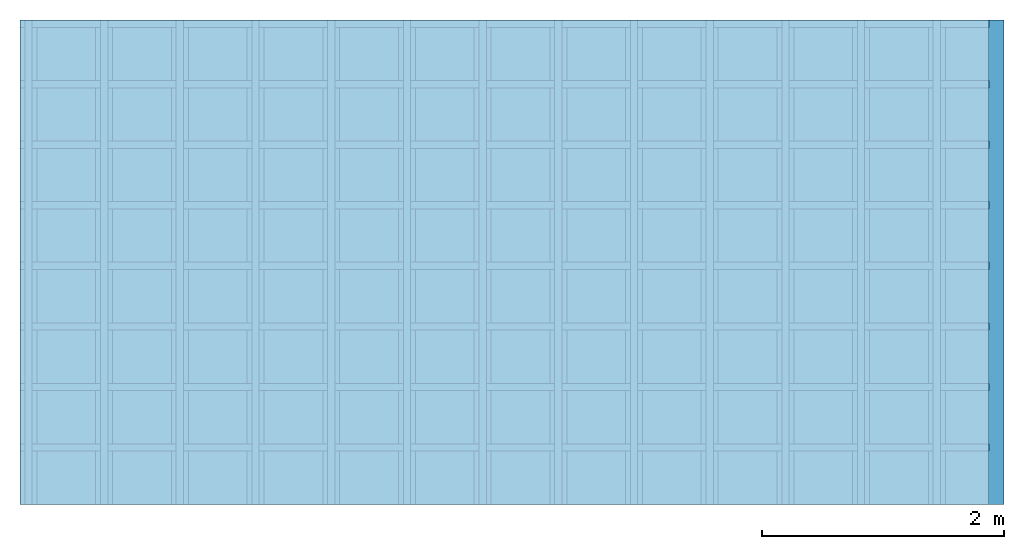
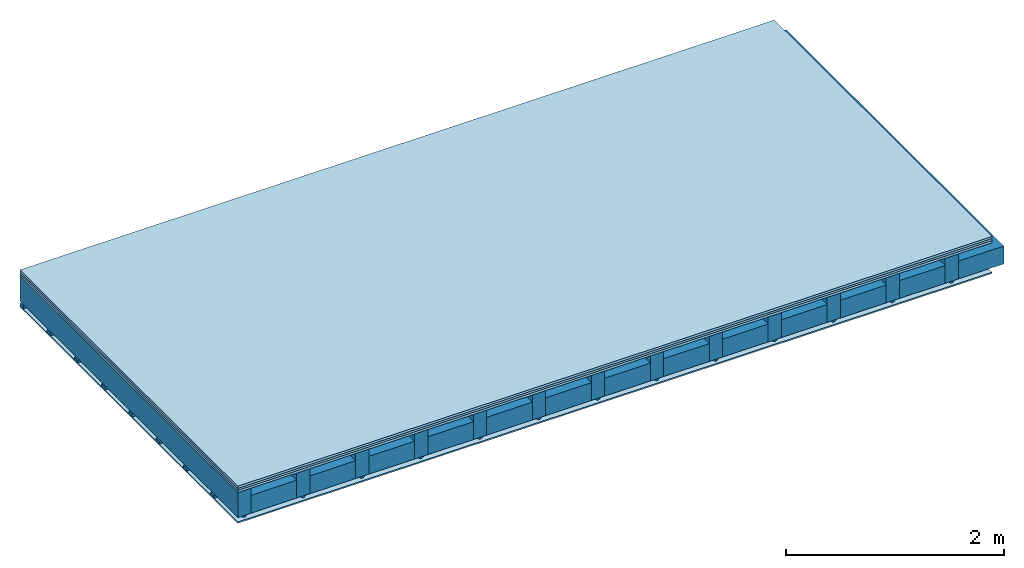
# One storey: 4 members, 4 plates, 1 element without a shape of its own.
"""IFC4 building model written with IfcOpenShell, lengths in metres."""

from ifc_helpers import new_model, si_unit, derived_unit, direction, frame, frame_2d, origin, origin_with_axes, place, context, project, spatial, polyline, rectangle, outline, extrude, material, layer, layer_set, type_object, element, aggregate, save


model = new_model("IFC4")

# Units and contexts
plan_context = context("Plan", 3, precision=1e-05, world=origin(), true_north=direction((0.0, 1.0)))
model_context = context("Model", 3, precision=1e-05, world=origin(), true_north=direction((0.0, 1.0)))
ifc_project = project(units=[si_unit("LENGTHUNIT", "METRE"), derived_unit("SOUNDPRESSUREUNIT", [(si_unit("PRESSUREUNIT", "PASCAL", prefix="MICRO"), 0)]), si_unit("ENERGYUNIT", "JOULE", prefix="MEGA"), si_unit("MASSUNIT", "GRAM", prefix="KILO"), derived_unit("THERMALTRANSMITTANCEUNIT", [(si_unit("POWERUNIT", "WATT"), 1), (si_unit("AREAUNIT", "SQUARE_METRE"), -1), (si_unit("THERMODYNAMICTEMPERATUREUNIT", "KELVIN"), -1)]), derived_unit("AREADENSITYUNIT", [(si_unit("MASSUNIT", "GRAM", prefix="KILO"), 1), (si_unit("AREAUNIT", "SQUARE_METRE"), -1)]), derived_unit("USERDEFINED", [(si_unit("ENERGYUNIT", "JOULE", prefix="MEGA"), 1), (si_unit("AREAUNIT", "SQUARE_METRE"), -1)])], contexts=[plan_context, model_context])

# Site, building, storey
site = spatial("IfcSite", under=ifc_project)
building_placement = place(None, origin())
building = spatial("IfcBuilding", under=site, at=building_placement)
storey_placement = place(building_placement, origin())
storey = spatial("IfcBuildingStorey", under=building, at=storey_placement)

# Slab, members, plates
ifc_material_1 = material(Name="Floor heating system Therm38 longitudinal", Category="03.007")
ifc_layer_1 = layer(ifc_material_1, 0.025, Name="On-material")
ifc_material_2 = material(Category="10.009")
ifc_layer_2 = layer(ifc_material_2, 0.022, Name="Impact sound insulation")
ifc_material_3 = material(Category="07.001")
ifc_layer_3 = layer(ifc_material_3, 0.025, Name="Sub-floor")
ifc_material_4 = material(Name="of the art")
ifc_layer_4 = layer(ifc_material_4, 0.0, Name="Bond")
ifc_layer_5 = layer(None, 0.28, Name="Supporting structure")
ifc_material_5 = material(Name="no composite action")
ifc_layer_6 = layer(ifc_material_5, 0.0, Name="Bond")
ifc_layer_7 = layer(None, 0.02, Name="Coupling")
ifc_layer_8 = layer(None, 0.03, Name="Battens / profiles")
ifc_material_6 = material(Name="Plasterboard type A", Category="03.008")
ifc_layer_9 = layer(ifc_material_6, 0.015, Name="Ceiling covering 1st layer")
ifc_material_7 = material(Name="joints", Category="04.017")
ifc_layer_10 = layer(ifc_material_7, 0.0, Name="Surface / treatment")
ifc_layer_set = layer_set([ifc_layer_1, ifc_layer_2, ifc_layer_3, ifc_layer_4, ifc_layer_5, ifc_layer_6, ifc_layer_7, ifc_layer_8, ifc_layer_9, ifc_layer_10])
slab_type = type_object("IfcSlabType", Name="A0139", PredefinedType="NOTDEFINED", material=ifc_layer_set)
slab_placement = place(None, frame((0.0, 0.0, 0.0), z_axis=(0.0, 0.0, -1.0), x_axis=(1.0, 0.0, 0.0)))
slab = element("IfcSlab", 1, at=slab_placement, inside=storey, type_object=slab_type, material=ifc_layer_set, Name="Slab #1")
ifc_material_8 = material()
member_1_placement = place(slab_placement, origin())
member_1 = element("IfcMember", 2, at=member_1_placement, material=ifc_material_8, Name="Supporting structure", context=plan_context, shape_type="SweptSolid", body=[
    extrude(rectangle(XDim=0.14, YDim=0.28, at=frame_2d((0.07, 0.14), x_axis=(1.0, 0.0))), frame((0.0, 4.0, 0.072), z_axis=(0.0, -1.0, 0.0), x_axis=(1.0, 0.0, 0.0)), (0.0, 0.0, 1.0), 4.0),
    extrude(rectangle(XDim=0.14, YDim=0.28, at=frame_2d((0.07, 0.14), x_axis=(1.0, 0.0))), frame((0.625, 4.0, 0.072), z_axis=(0.0, -1.0, 0.0), x_axis=(1.0, 0.0, 0.0)), (0.0, 0.0, 1.0), 4.0),
    extrude(rectangle(XDim=0.14, YDim=0.28, at=frame_2d((0.07, 0.14), x_axis=(1.0, 0.0))), frame((1.25, 4.0, 0.072), z_axis=(0.0, -1.0, 0.0), x_axis=(1.0, 0.0, 0.0)), (0.0, 0.0, 1.0), 4.0),
    extrude(rectangle(XDim=0.14, YDim=0.28, at=frame_2d((0.07, 0.14), x_axis=(1.0, 0.0))), frame((1.875, 4.0, 0.072), z_axis=(0.0, -1.0, 0.0), x_axis=(1.0, 0.0, 0.0)), (0.0, 0.0, 1.0), 4.0),
    extrude(rectangle(XDim=0.14, YDim=0.28, at=frame_2d((0.07, 0.14), x_axis=(1.0, 0.0))), frame((2.5, 4.0, 0.072), z_axis=(0.0, -1.0, 0.0), x_axis=(1.0, 0.0, 0.0)), (0.0, 0.0, 1.0), 4.0),
    extrude(rectangle(XDim=0.14, YDim=0.28, at=frame_2d((0.07, 0.14), x_axis=(1.0, 0.0))), frame((3.125, 4.0, 0.072), z_axis=(0.0, -1.0, 0.0), x_axis=(1.0, 0.0, 0.0)), (0.0, 0.0, 1.0), 4.0),
    extrude(rectangle(XDim=0.14, YDim=0.28, at=frame_2d((0.07, 0.14), x_axis=(1.0, 0.0))), frame((3.75, 4.0, 0.072), z_axis=(0.0, -1.0, 0.0), x_axis=(1.0, 0.0, 0.0)), (0.0, 0.0, 1.0), 4.0),
    extrude(rectangle(XDim=0.14, YDim=0.28, at=frame_2d((0.07, 0.14), x_axis=(1.0, 0.0))), frame((4.375, 4.0, 0.072), z_axis=(0.0, -1.0, 0.0), x_axis=(1.0, 0.0, 0.0)), (0.0, 0.0, 1.0), 4.0),
    extrude(rectangle(XDim=0.14, YDim=0.28, at=frame_2d((0.07, 0.14), x_axis=(1.0, 0.0))), frame((5.0, 4.0, 0.072), z_axis=(0.0, -1.0, 0.0), x_axis=(1.0, 0.0, 0.0)), (0.0, 0.0, 1.0), 4.0),
    extrude(rectangle(XDim=0.14, YDim=0.28, at=frame_2d((0.07, 0.14), x_axis=(1.0, 0.0))), frame((5.625, 4.0, 0.072), z_axis=(0.0, -1.0, 0.0), x_axis=(1.0, 0.0, 0.0)), (0.0, 0.0, 1.0), 4.0),
    extrude(rectangle(XDim=0.14, YDim=0.28, at=frame_2d((0.07, 0.14), x_axis=(1.0, 0.0))), frame((6.25, 4.0, 0.072), z_axis=(0.0, -1.0, 0.0), x_axis=(1.0, 0.0, 0.0)), (0.0, 0.0, 1.0), 4.0),
    extrude(rectangle(XDim=0.14, YDim=0.28, at=frame_2d((0.07, 0.14), x_axis=(1.0, 0.0))), frame((6.875, 4.0, 0.072), z_axis=(0.0, -1.0, 0.0), x_axis=(1.0, 0.0, 0.0)), (0.0, 0.0, 1.0), 4.0),
    extrude(rectangle(XDim=0.14, YDim=0.28, at=frame_2d((0.07, 0.14), x_axis=(1.0, 0.0))), frame((7.5, 4.0, 0.072), z_axis=(0.0, -1.0, 0.0), x_axis=(1.0, 0.0, 0.0)), (0.0, 0.0, 1.0), 4.0),
])
ifc_material_9 = material()
member_2_placement = place(slab_placement, origin())
member_2 = element("IfcMember", 3, at=member_2_placement, material=ifc_material_9, Name="Cavity", context=plan_context, shape_type="SweptSolid", body=[
    extrude(rectangle(XDim=0.485, YDim=0.2, at=frame_2d((0.2425, 0.1), x_axis=(1.0, 0.0))), frame((0.14, 4.0, 0.152), z_axis=(0.0, -1.0, 0.0), x_axis=(1.0, 0.0, 0.0)), (0.0, 0.0, 1.0), 4.0),
    extrude(rectangle(XDim=0.485, YDim=0.2, at=frame_2d((0.2425, 0.1), x_axis=(1.0, 0.0))), frame((0.765, 4.0, 0.152), z_axis=(0.0, -1.0, 0.0), x_axis=(1.0, 0.0, 0.0)), (0.0, 0.0, 1.0), 4.0),
    extrude(rectangle(XDim=0.485, YDim=0.2, at=frame_2d((0.2425, 0.1), x_axis=(1.0, 0.0))), frame((1.39, 4.0, 0.152), z_axis=(0.0, -1.0, 0.0), x_axis=(1.0, 0.0, 0.0)), (0.0, 0.0, 1.0), 4.0),
    extrude(rectangle(XDim=0.485, YDim=0.2, at=frame_2d((0.2425, 0.1), x_axis=(1.0, 0.0))), frame((2.015, 4.0, 0.152), z_axis=(0.0, -1.0, 0.0), x_axis=(1.0, 0.0, 0.0)), (0.0, 0.0, 1.0), 4.0),
    extrude(rectangle(XDim=0.485, YDim=0.2, at=frame_2d((0.2425, 0.1), x_axis=(1.0, 0.0))), frame((2.64, 4.0, 0.152), z_axis=(0.0, -1.0, 0.0), x_axis=(1.0, 0.0, 0.0)), (0.0, 0.0, 1.0), 4.0),
    extrude(rectangle(XDim=0.485, YDim=0.2, at=frame_2d((0.2425, 0.1), x_axis=(1.0, 0.0))), frame((3.265, 4.0, 0.152), z_axis=(0.0, -1.0, 0.0), x_axis=(1.0, 0.0, 0.0)), (0.0, 0.0, 1.0), 4.0),
    extrude(rectangle(XDim=0.485, YDim=0.2, at=frame_2d((0.2425, 0.1), x_axis=(1.0, 0.0))), frame((3.89, 4.0, 0.152), z_axis=(0.0, -1.0, 0.0), x_axis=(1.0, 0.0, 0.0)), (0.0, 0.0, 1.0), 4.0),
    extrude(rectangle(XDim=0.485, YDim=0.2, at=frame_2d((0.2425, 0.1), x_axis=(1.0, 0.0))), frame((4.515, 4.0, 0.152), z_axis=(0.0, -1.0, 0.0), x_axis=(1.0, 0.0, 0.0)), (0.0, 0.0, 1.0), 4.0),
    extrude(rectangle(XDim=0.485, YDim=0.2, at=frame_2d((0.2425, 0.1), x_axis=(1.0, 0.0))), frame((5.14, 4.0, 0.152), z_axis=(0.0, -1.0, 0.0), x_axis=(1.0, 0.0, 0.0)), (0.0, 0.0, 1.0), 4.0),
    extrude(rectangle(XDim=0.485, YDim=0.2, at=frame_2d((0.2425, 0.1), x_axis=(1.0, 0.0))), frame((5.765, 4.0, 0.152), z_axis=(0.0, -1.0, 0.0), x_axis=(1.0, 0.0, 0.0)), (0.0, 0.0, 1.0), 4.0),
    extrude(rectangle(XDim=0.485, YDim=0.2, at=frame_2d((0.2425, 0.1), x_axis=(1.0, 0.0))), frame((6.39, 4.0, 0.152), z_axis=(0.0, -1.0, 0.0), x_axis=(1.0, 0.0, 0.0)), (0.0, 0.0, 1.0), 4.0),
    extrude(rectangle(XDim=0.485, YDim=0.2, at=frame_2d((0.2425, 0.1), x_axis=(1.0, 0.0))), frame((7.015, 4.0, 0.152), z_axis=(0.0, -1.0, 0.0), x_axis=(1.0, 0.0, 0.0)), (0.0, 0.0, 1.0), 4.0),
    extrude(rectangle(XDim=0.485, YDim=0.2, at=frame_2d((0.2425, 0.1), x_axis=(1.0, 0.0))), frame((7.64, 4.0, 0.152), z_axis=(0.0, -1.0, 0.0), x_axis=(1.0, 0.0, 0.0)), (0.0, 0.0, 1.0), 4.0),
])
ifc_material_10 = material()
member_3_placement = place(slab_placement, origin())
member_3 = element("IfcMember", 4, at=member_3_placement, material=ifc_material_10, Name="Coupling", context=plan_context, shape_type="SweptSolid", body=[
    extrude(outline(polyline([(0.0, 0.0), (0.06, 0.0), (0.04, 0.02), (0.02, 0.02), (0.0, 0.0)])), frame((0.04, 4.0, 0.352), z_axis=(0.0, -1.0, 0.0), x_axis=(1.0, 0.0, 0.0)), (0.0, 0.0, 1.0), 4.0),
    extrude(outline(polyline([(0.0, 0.0), (0.06, 0.0), (0.04, 0.02), (0.02, 0.02), (0.0, 0.0)])), frame((0.665, 4.0, 0.352), z_axis=(0.0, -1.0, 0.0), x_axis=(1.0, 0.0, 0.0)), (0.0, 0.0, 1.0), 4.0),
    extrude(outline(polyline([(0.0, 0.0), (0.06, 0.0), (0.04, 0.02), (0.02, 0.02), (0.0, 0.0)])), frame((1.29, 4.0, 0.352), z_axis=(0.0, -1.0, 0.0), x_axis=(1.0, 0.0, 0.0)), (0.0, 0.0, 1.0), 4.0),
    extrude(outline(polyline([(0.0, 0.0), (0.06, 0.0), (0.04, 0.02), (0.02, 0.02), (0.0, 0.0)])), frame((1.915, 4.0, 0.352), z_axis=(0.0, -1.0, 0.0), x_axis=(1.0, 0.0, 0.0)), (0.0, 0.0, 1.0), 4.0),
    extrude(outline(polyline([(0.0, 0.0), (0.06, 0.0), (0.04, 0.02), (0.02, 0.02), (0.0, 0.0)])), frame((2.54, 4.0, 0.352), z_axis=(0.0, -1.0, 0.0), x_axis=(1.0, 0.0, 0.0)), (0.0, 0.0, 1.0), 4.0),
    extrude(outline(polyline([(0.0, 0.0), (0.06, 0.0), (0.04, 0.02), (0.02, 0.02), (0.0, 0.0)])), frame((3.165, 4.0, 0.352), z_axis=(0.0, -1.0, 0.0), x_axis=(1.0, 0.0, 0.0)), (0.0, 0.0, 1.0), 4.0),
    extrude(outline(polyline([(0.0, 0.0), (0.06, 0.0), (0.04, 0.02), (0.02, 0.02), (0.0, 0.0)])), frame((3.79, 4.0, 0.352), z_axis=(0.0, -1.0, 0.0), x_axis=(1.0, 0.0, 0.0)), (0.0, 0.0, 1.0), 4.0),
    extrude(outline(polyline([(0.0, 0.0), (0.06, 0.0), (0.04, 0.02), (0.02, 0.02), (0.0, 0.0)])), frame((4.415, 4.0, 0.352), z_axis=(0.0, -1.0, 0.0), x_axis=(1.0, 0.0, 0.0)), (0.0, 0.0, 1.0), 4.0),
    extrude(outline(polyline([(0.0, 0.0), (0.06, 0.0), (0.04, 0.02), (0.02, 0.02), (0.0, 0.0)])), frame((5.04, 4.0, 0.352), z_axis=(0.0, -1.0, 0.0), x_axis=(1.0, 0.0, 0.0)), (0.0, 0.0, 1.0), 4.0),
    extrude(outline(polyline([(0.0, 0.0), (0.06, 0.0), (0.04, 0.02), (0.02, 0.02), (0.0, 0.0)])), frame((5.665, 4.0, 0.352), z_axis=(0.0, -1.0, 0.0), x_axis=(1.0, 0.0, 0.0)), (0.0, 0.0, 1.0), 4.0),
    extrude(outline(polyline([(0.0, 0.0), (0.06, 0.0), (0.04, 0.02), (0.02, 0.02), (0.0, 0.0)])), frame((6.29, 4.0, 0.352), z_axis=(0.0, -1.0, 0.0), x_axis=(1.0, 0.0, 0.0)), (0.0, 0.0, 1.0), 4.0),
    extrude(outline(polyline([(0.0, 0.0), (0.06, 0.0), (0.04, 0.02), (0.02, 0.02), (0.0, 0.0)])), frame((6.915, 4.0, 0.352), z_axis=(0.0, -1.0, 0.0), x_axis=(1.0, 0.0, 0.0)), (0.0, 0.0, 1.0), 4.0),
    extrude(outline(polyline([(0.0, 0.0), (0.06, 0.0), (0.04, 0.02), (0.02, 0.02), (0.0, 0.0)])), frame((7.54, 4.0, 0.352), z_axis=(0.0, -1.0, 0.0), x_axis=(1.0, 0.0, 0.0)), (0.0, 0.0, 1.0), 4.0),
])
ifc_material_11 = material()
member_4_placement = place(slab_placement, origin())
member_4 = element("IfcMember", 5, at=member_4_placement, material=ifc_material_11, Name="Battens / profiles", context=plan_context, shape_type="SweptSolid", body=[
    extrude(rectangle(XDim=0.06, YDim=0.03, at=frame_2d((0.03, 0.015), x_axis=(1.0, 0.0))), frame((0.0, 0.0, 0.372), z_axis=(1.0, 0.0, 0.0), x_axis=(0.0, 1.0, 0.0)), (0.0, 0.0, 1.0), 8.0),
    extrude(rectangle(XDim=0.06, YDim=0.03, at=frame_2d((0.03, 0.015), x_axis=(1.0, 0.0))), frame((0.0, 0.5, 0.372), z_axis=(1.0, 0.0, 0.0), x_axis=(0.0, 1.0, 0.0)), (0.0, 0.0, 1.0), 8.0),
    extrude(rectangle(XDim=0.06, YDim=0.03, at=frame_2d((0.03, 0.015), x_axis=(1.0, 0.0))), frame((0.0, 1.0, 0.372), z_axis=(1.0, 0.0, 0.0), x_axis=(0.0, 1.0, 0.0)), (0.0, 0.0, 1.0), 8.0),
    extrude(rectangle(XDim=0.06, YDim=0.03, at=frame_2d((0.03, 0.015), x_axis=(1.0, 0.0))), frame((0.0, 1.5, 0.372), z_axis=(1.0, 0.0, 0.0), x_axis=(0.0, 1.0, 0.0)), (0.0, 0.0, 1.0), 8.0),
    extrude(rectangle(XDim=0.06, YDim=0.03, at=frame_2d((0.03, 0.015), x_axis=(1.0, 0.0))), frame((0.0, 2.0, 0.372), z_axis=(1.0, 0.0, 0.0), x_axis=(0.0, 1.0, 0.0)), (0.0, 0.0, 1.0), 8.0),
    extrude(rectangle(XDim=0.06, YDim=0.03, at=frame_2d((0.03, 0.015), x_axis=(1.0, 0.0))), frame((0.0, 2.5, 0.372), z_axis=(1.0, 0.0, 0.0), x_axis=(0.0, 1.0, 0.0)), (0.0, 0.0, 1.0), 8.0),
    extrude(rectangle(XDim=0.06, YDim=0.03, at=frame_2d((0.03, 0.015), x_axis=(1.0, 0.0))), frame((0.0, 3.0, 0.372), z_axis=(1.0, 0.0, 0.0), x_axis=(0.0, 1.0, 0.0)), (0.0, 0.0, 1.0), 8.0),
    extrude(rectangle(XDim=0.06, YDim=0.03, at=frame_2d((0.03, 0.015), x_axis=(1.0, 0.0))), frame((0.0, 3.5, 0.372), z_axis=(1.0, 0.0, 0.0), x_axis=(0.0, 1.0, 0.0)), (0.0, 0.0, 1.0), 8.0),
])
plate_1_placement = place(slab_placement, origin())
plate_1 = element("IfcPlate", 6, at=plate_1_placement, material=ifc_material_1, Name="On-material", context=plan_context, shape_type="SweptSolid", body=[
    extrude(rectangle(XDim=8.0, YDim=4.0, at=frame_2d((4.0, 2.0), x_axis=(1.0, 0.0))), origin_with_axes(), (0.0, 0.0, 1.0), 0.025),
])
plate_2_placement = place(slab_placement, origin())
plate_2 = element("IfcPlate", 7, at=plate_2_placement, material=ifc_material_2, Name="Impact sound insulation", context=plan_context, shape_type="SweptSolid", body=[
    extrude(rectangle(XDim=8.0, YDim=4.0, at=frame_2d((4.0, 2.0), x_axis=(1.0, 0.0))), frame((0.0, 0.0, 0.025), z_axis=(0.0, 0.0, 1.0), x_axis=(1.0, 0.0, 0.0)), (0.0, 0.0, 1.0), 0.022),
])
plate_3_placement = place(slab_placement, origin())
plate_3 = element("IfcPlate", 8, at=plate_3_placement, material=ifc_material_3, Name="Sub-floor", context=plan_context, shape_type="SweptSolid", body=[
    extrude(rectangle(XDim=8.0, YDim=4.0, at=frame_2d((4.0, 2.0), x_axis=(1.0, 0.0))), frame((0.0, 0.0, 0.047), z_axis=(0.0, 0.0, 1.0), x_axis=(1.0, 0.0, 0.0)), (0.0, 0.0, 1.0), 0.025),
])
plate_4_placement = place(slab_placement, origin())
plate_4 = element("IfcPlate", 9, at=plate_4_placement, material=ifc_material_6, Name="Ceiling covering 1st layer", context=plan_context, shape_type="SweptSolid", body=[
    extrude(rectangle(XDim=8.0, YDim=4.0, at=frame_2d((4.0, 2.0), x_axis=(1.0, 0.0))), frame((0.0, 0.0, 0.402), z_axis=(0.0, 0.0, 1.0), x_axis=(1.0, 0.0, 0.0)), (0.0, 0.0, 1.0), 0.015),
])
aggregate(slab, [plate_1, plate_2, plate_3, member_1, member_2, member_3, member_4, plate_4])

save(model, "model.ifc")
